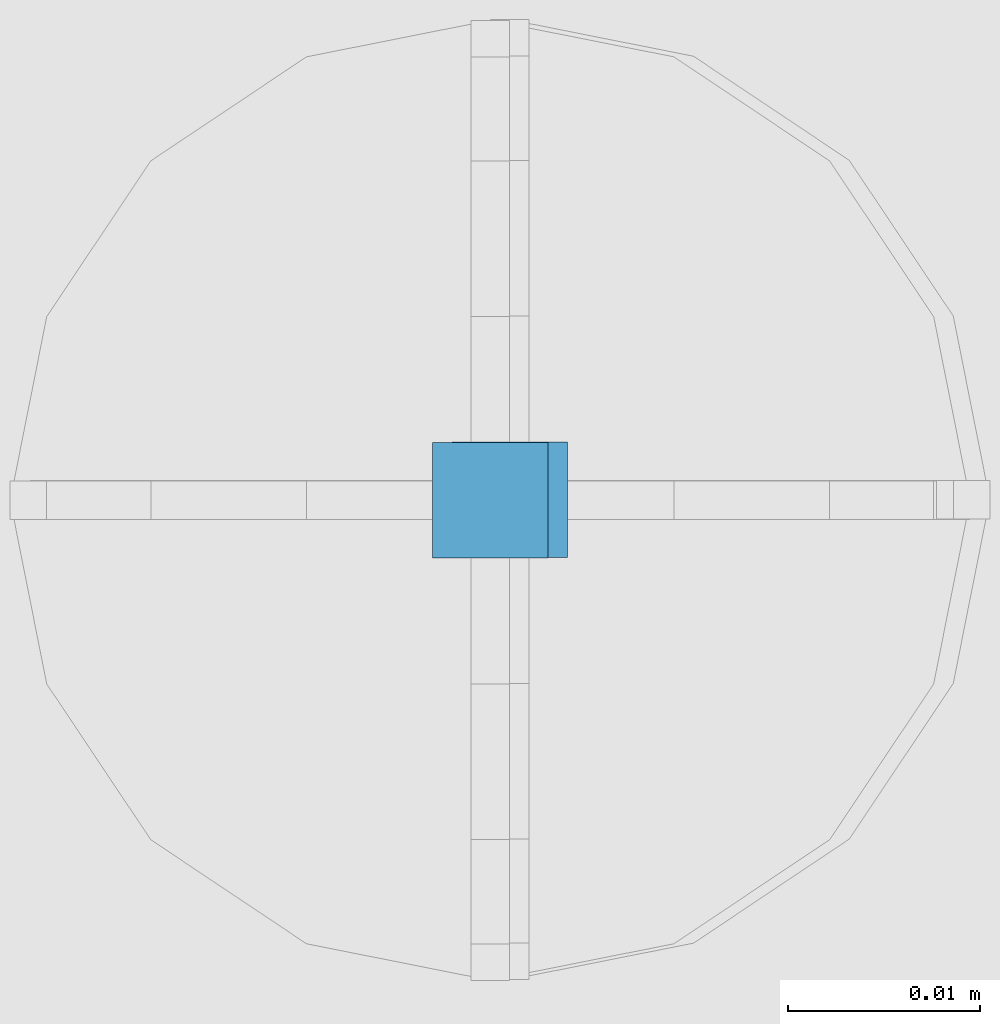
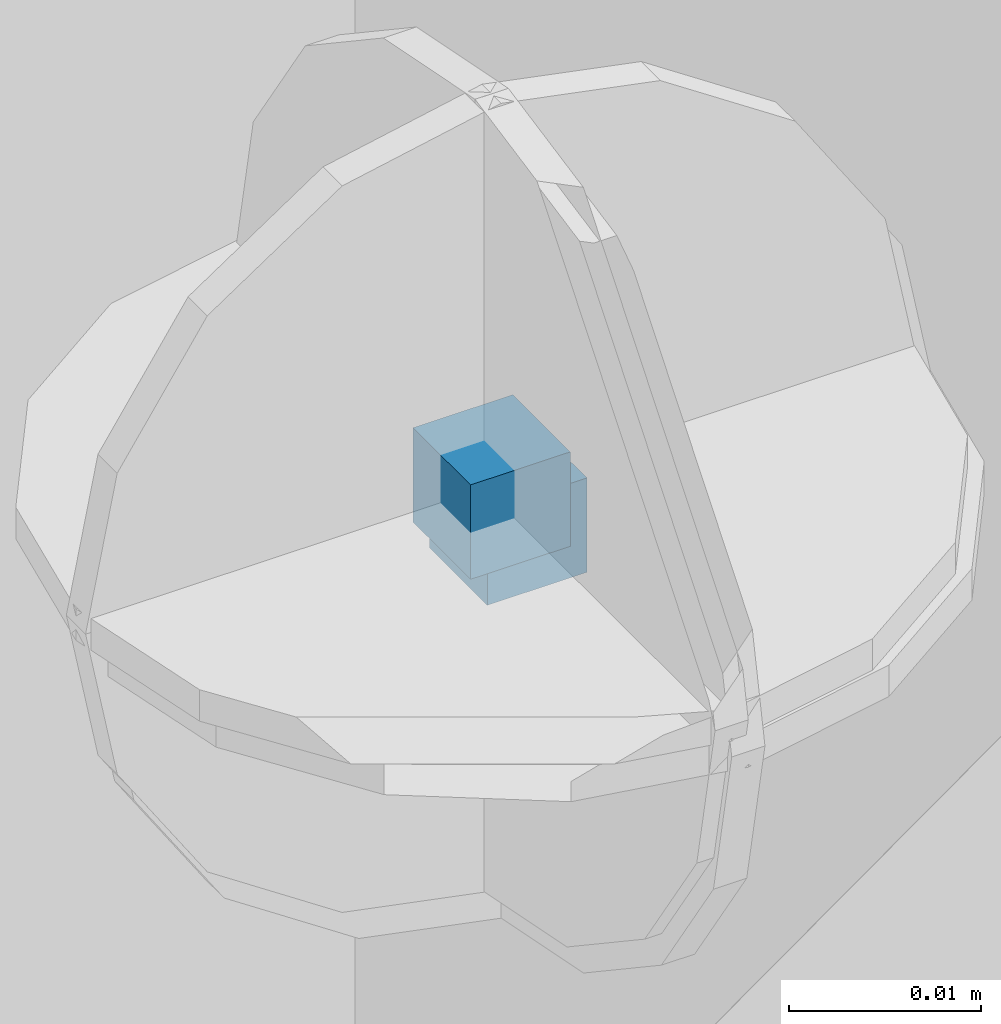
# One storey, part 75 of 350: 2 columns, 3 elements without a shape of their own.
"""IFC2X3 building model written with IfcOpenShell, lengths in millimetres."""

import ifcopenshell
import ifcopenshell.guid

model = None  # the IFC model being written
_history = None  # IfcOwnerHistory: only IFC2X3 demands one
_inside = {}  # id of a spatial element -> (the spatial element, [elements in it])
_under = {}  # id of a project, library or spatial element -> (it, [spatial elements below it])
_declared = {}  # id of a project -> (the project, [libraries it declares])
_typed = {}  # id of a type object -> (the type object, [elements of that type])
_made_of = {}  # id of a material, layer set ... -> (it, [elements and type objects made of it])


def new_model(schema):
    """Start an empty IFC model of exactly this schema.

    Asked for "IFC4X3", IfcOpenShell would pick the latest addendum, in which some entities
    have other attributes; the version numbers below select the first issue.
    IFC2X3 requires an IfcOwnerHistory on every rooted entity: one is made here for all.
    """
    global model, _history
    if schema == "IFC4X3":
        model = ifcopenshell.file(schema_version=(4, 3, 0, 0))
    else:
        model = ifcopenshell.file(schema=schema)
    _inside.clear()
    _under.clear()
    _declared.clear()
    _typed.clear()
    _made_of.clear()
    _history = None
    if model.schema == "IFC2X3":
        org = make("IfcOrganization", Name="unknown")
        user = make(
            "IfcPersonAndOrganization",
            ThePerson=make("IfcPerson", FamilyName="unknown"),
            TheOrganization=org,
        )
        app = make(
            "IfcApplication",
            ApplicationDeveloper=org,
            Version="unknown",
            ApplicationFullName="unknown",
            ApplicationIdentifier="unknown",
        )
        _history = make(
            "IfcOwnerHistory",
            OwningUser=user,
            OwningApplication=app,
            ChangeAction="ADDED",
            CreationDate=0,
        )
    return model


def make(cls, **values):
    """One entity of the class cls with the attributes given. An attribute that is None is left unset."""
    return model.create_entity(
        cls, **{name: value for name, value in values.items() if value is not None}
    )


def rooted(cls, **values):
    """An entity with a GlobalId (a new one), such as an element, a storey or a relation."""
    return make(cls, GlobalId=ifcopenshell.guid.new(), OwnerHistory=_history, **values)


def si_unit(unit_type, name, prefix=None):
    """IfcSIUnit, for example si_unit("LENGTHUNIT", "METRE", prefix="MILLI")."""
    return make("IfcSIUnit", UnitType=unit_type, Prefix=prefix, Name=name)


def assignment(units):
    """IfcUnitAssignment: the units of a project."""
    return None if units is None else make("IfcUnitAssignment", Units=units)


def point(xyz):
    """IfcCartesianPoint."""
    return None if xyz is None else make("IfcCartesianPoint", Coordinates=xyz)


def direction(xyz):
    """IfcDirection."""
    return None if xyz is None else make("IfcDirection", DirectionRatios=xyz)


def frame(location, z_axis=None, x_axis=None):
    """IfcAxis2Placement3D, a coordinate frame: its origin and axes. An axis left out is left unset."""
    return make(
        "IfcAxis2Placement3D",
        Location=point(location),
        Axis=direction(z_axis),
        RefDirection=direction(x_axis),
    )


def origin_with_axes():
    """The frame at (0, 0, 0) with the z axis (0, 0, 1) and the x axis (1, 0, 0) written out."""
    return frame((0.0, 0.0, 0.0), z_axis=(0.0, 0.0, 1.0), x_axis=(1.0, 0.0, 0.0))


def place(relative_to, where):
    """IfcLocalPlacement: puts the frame where relative to a parent placement (None: the world)."""
    return make(
        "IfcLocalPlacement", PlacementRelTo=relative_to, RelativePlacement=where
    )


def context(
    kind, dimensions, precision=None, world=None, true_north=None, identifier=None
):
    """IfcGeometricRepresentationContext, for example the 3D "Model" context."""
    return make(
        "IfcGeometricRepresentationContext",
        ContextIdentifier=identifier,
        ContextType=kind,
        CoordinateSpaceDimension=dimensions,
        Precision=precision,
        WorldCoordinateSystem=world,
        TrueNorth=true_north,
    )


def subcontext(parent, identifier, kind, view, scale=None):
    """IfcGeometricRepresentationSubContext, for example "Body" below "Model"."""
    return make(
        "IfcGeometricRepresentationSubContext",
        ContextIdentifier=identifier,
        ContextType=kind,
        ParentContext=parent,
        TargetScale=scale,
        TargetView=view,
    )


def project(units=None, contexts=None):
    """IfcProject with its units and contexts."""
    return rooted(
        "IfcProject",
        Name="project",
        RepresentationContexts=contexts,
        UnitsInContext=assignment(units),
    )


def spatial(cls, under=None, at=None, **own):
    """A site, building, storey or space (cls), placed at a placement, below another one or the project."""
    s = rooted(cls, ObjectPlacement=at, **own)
    if under is not None:
        _under.setdefault(under.id(), (under, []))[1].append(s)
    return s


def faces_of(points, faces, orient=None, outer=None):
    """IfcFace entities. A face is a list of loops; a loop is a list of indices into points, from 0.

    orient and outer hold one flag for each loop. By default every Orientation is true, the
    first loop of a face is its IfcFaceOuterBound and the others are IfcFaceBound.
    """
    made = []
    for i, loops in enumerate(faces):
        bounds = []
        for j, loop in enumerate(loops):
            is_outer = j == 0 if outer is None else outer[i][j]
            bounds.append(
                make(
                    "IfcFaceOuterBound" if is_outer else "IfcFaceBound",
                    Bound=make("IfcPolyLoop", Polygon=[points[k] for k in loop]),
                    Orientation=True if orient is None else orient[i][j],
                )
            )
        made.append(make("IfcFace", Bounds=bounds))
    return made


def faceted_brep(points, faces, orient=None, outer=None, voids=None):
    """IfcFacetedBrep: a solid bounded by flat faces; with voids (closed shells), ...WithVoids."""
    shared = [point(p) for p in points]
    hull = make("IfcClosedShell", CfsFaces=faces_of(shared, faces, orient, outer))
    if voids is None:
        return make("IfcFacetedBrep", Outer=hull)
    return make(
        "IfcFacetedBrepWithVoids",
        Outer=hull,
        Voids=[
            make(cls, CfsFaces=faces_of(shared, fs, o, b)) for cls, fs, o, b in voids
        ],
    )


def shape(context_of_items, identifier, shape_type, items):
    """IfcShapeRepresentation: the items that make up one representation, for example the "Body"."""
    return make(
        "IfcShapeRepresentation",
        ContextOfItems=context_of_items,
        RepresentationIdentifier=identifier,
        RepresentationType=shape_type,
        Items=items,
    )


def material(Name=None, Category=None):
    """IfcMaterial."""
    return make("IfcMaterial", Name=Name, Category=Category)


def made_of(thing, what):
    """Note that an element or type object is made of a material, layer set ...; save() writes the relation."""
    if what is not None:
        _made_of.setdefault(what.id(), (what, []))[1].append(thing)
    return thing


def type_object(cls, material=None, **own):
    """A type object (cls), such as IfcWallType, which elements share."""
    return made_of(rooted(cls, **own), material)


def element(
    cls,
    number,
    at=None,
    inside=None,
    cuts=None,
    type_object=None,
    material=None,
    context=None,
    identifier="Body",
    shape_type=None,
    held_by="IfcProductDefinitionShape",
    body=None,
    shapes=None,
    **own,
):
    """One element of the class cls, such as IfcWall. Its Tag is "e" and its number.

    at: its placement. inside: the storey or other place that contains it. cuts: it is an
    opening in that element (IfcRelVoidsElement). A single representation is given by context,
    identifier, shape_type and body (its items); several are given by shapes. held_by: the class
    of the entity that holds the representations. save() writes the other relations.
    """
    e = rooted(cls, Tag="e%d" % number, ObjectPlacement=at, **own)
    if body is not None:
        shapes = [shape(context, identifier, shape_type, body)]
    if shapes is not None:
        e.Representation = make(held_by, Representations=shapes)
    if inside is not None:
        _inside.setdefault(inside.id(), (inside, []))[1].append(e)
    if cuts is not None:
        rooted(
            "IfcRelVoidsElement", RelatingBuildingElement=cuts, RelatedOpeningElement=e
        )
    if type_object is not None:
        _typed.setdefault(type_object.id(), (type_object, []))[1].append(e)
    return made_of(e, material)


def aggregate(whole, parts):
    """IfcRelAggregates: a whole, such as a stair, and the parts it consists of."""
    return rooted("IfcRelAggregates", RelatingObject=whole, RelatedObjects=parts)


def save(model, path):
    """Write the relations noted so far, then the file.

    IfcRelAggregates (storeys below a building ...), IfcRelContainedInSpatialStructure (elements
    in a storey), IfcRelDefinesByType, IfcRelAssociatesMaterial and IfcRelDeclares: one each for
    every whole, place, type object, material and project.
    """
    for whole, parts in _under.values():
        aggregate(whole, parts)
    for where, things in _inside.values():
        rooted(
            "IfcRelContainedInSpatialStructure",
            RelatedElements=things,
            RelatingStructure=where,
        )
    for kind, things in _typed.values():
        rooted("IfcRelDefinesByType", RelatedObjects=things, RelatingType=kind)
    for what, things in _made_of.values():
        rooted("IfcRelAssociatesMaterial", RelatedObjects=things, RelatingMaterial=what)
    for by, libraries in _declared.values():
        rooted("IfcRelDeclares", RelatingContext=by, RelatedDefinitions=libraries)
    model.write(path)


model = new_model("IFC2X3")

# Units and contexts
model_context = context("Model", 3, precision=1e-05, world=origin_with_axes())
body_context = subcontext(model_context, "Body", "Model", "MODEL_VIEW")
ifc_project = project(units=[si_unit("LENGTHUNIT", "METRE", prefix="MILLI"), si_unit("AREAUNIT", "SQUARE_METRE"), si_unit("VOLUMEUNIT", "CUBIC_METRE"), si_unit("MASSUNIT", "GRAM", prefix="KILO"), si_unit("TIMEUNIT", "SECOND"), si_unit("PLANEANGLEUNIT", "RADIAN"), si_unit("SOLIDANGLEUNIT", "STERADIAN"), si_unit("THERMODYNAMICTEMPERATUREUNIT", "DEGREE_CELSIUS"), si_unit("LUMINOUSINTENSITYUNIT", "LUMEN")], contexts=[model_context])

# Site, building, storey
site_placement = place(None, origin_with_axes())
site = spatial("IfcSite", under=ifc_project, at=site_placement, CompositionType="ELEMENT")
building_placement = place(site_placement, origin_with_axes())
building = spatial("IfcBuilding", under=site, at=building_placement, CompositionType="ELEMENT")
storey_placement = place(building_placement, origin_with_axes())
storey = spatial("IfcBuildingStorey", under=building, at=storey_placement, Name="2", CompositionType="ELEMENT", Elevation=0.0)

# Assemblies, columns
assembly_1_placement = place(storey_placement, origin_with_axes())
assembly_1 = element("IfcElementAssembly", 1, at=assembly_1_placement, inside=storey, AssemblyPlace="NOTDEFINED", PredefinedType="REINFORCEMENT_UNIT")
assembly_2_placement = place(assembly_1_placement, origin_with_axes())
assembly_2 = element("IfcElementAssembly", 2, at=assembly_2_placement, Name="Steel Assembly", AssemblyPlace="NOTDEFINED", PredefinedType="RIGID_FRAME")
ifc_material = material(Name="STEEL/Steel_Undefined")
column_type = type_object("IfcColumnType", PredefinedType="NOTDEFINED")
column_1_placement = place(assembly_2_placement, frame((19805.3672816511, 20613.5564077389, 87731.5262892386), z_axis=(0.0, -1.0, 0.0), x_axis=(0.0, 0.0, 1.0)))
column_1 = element("IfcColumn", 3, at=column_1_placement, type_object=column_type, material=ifc_material, Name="PP", context=body_context, shape_type="Brep", body=[
    faceted_brep([(0.0, 3.0, -3.0), (0.0, 2.99999999999636, 3.0), (6.0, 2.99999999999636, 3.0), (6.0, 3.0, -3.0), (0.0, -3.00000000000364, 3.0), (6.0, -3.00000000000364, 3.0), (0.0, -3.0, -3.0), (6.0, -3.0, -3.0)], [[[0, 1, 2, 3]], [[1, 4, 5, 2]], [[4, 6, 7, 5]], [[6, 0, 3, 7]], [[5, 7, 3, 2]], [[6, 4, 1, 0]]]),
])
aggregate(assembly_2, [column_1])
assembly_3_placement = place(assembly_1_placement, origin_with_axes())
assembly_3 = element("IfcElementAssembly", 4, at=assembly_3_placement, Name="Steel Assembly", AssemblyPlace="NOTDEFINED", PredefinedType="RIGID_FRAME")
aggregate(assembly_1, [assembly_2, assembly_3])
column_2_placement = place(assembly_3_placement, frame((19806.3888800542, 20613.5887932168, 87729.4935861413), z_axis=(0.0, -1.0, 0.0), x_axis=(0.0, 0.0, 1.0)))
column_2 = element("IfcColumn", 5, at=column_2_placement, type_object=column_type, material=ifc_material, Name="PP", context=body_context, shape_type="Brep", body=[
    faceted_brep([(0.0, 3.0, -3.0), (0.0, 2.99999999999636, 3.0), (6.0, 2.99999999999636, 3.0), (6.0, 3.0, -3.0), (0.0, -3.00000000000364, 3.0), (6.0, -3.00000000000364, 3.0), (0.0, -3.0, -3.0), (6.0, -3.0, -3.0)], [[[0, 1, 2, 3]], [[1, 4, 5, 2]], [[4, 6, 7, 5]], [[6, 0, 3, 7]], [[5, 7, 3, 2]], [[6, 4, 1, 0]]]),
])
aggregate(assembly_3, [column_2])

save(model, "model.ifc")
